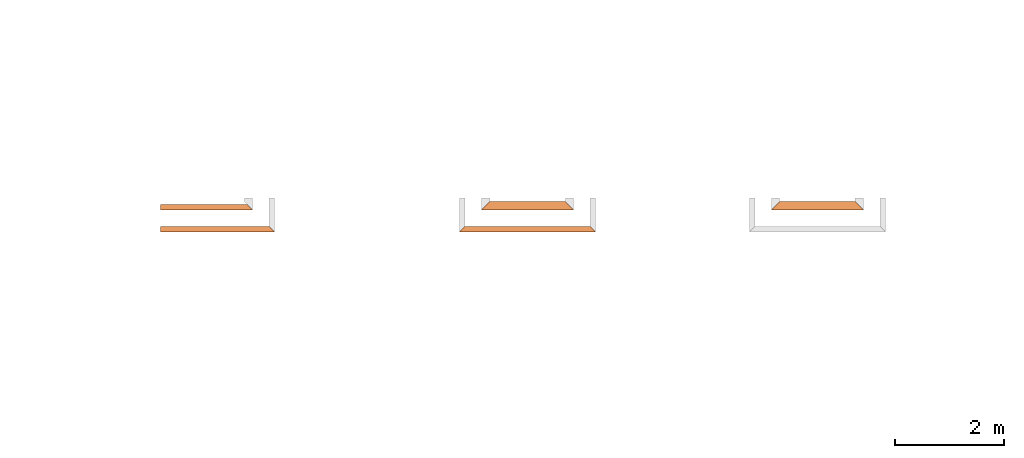
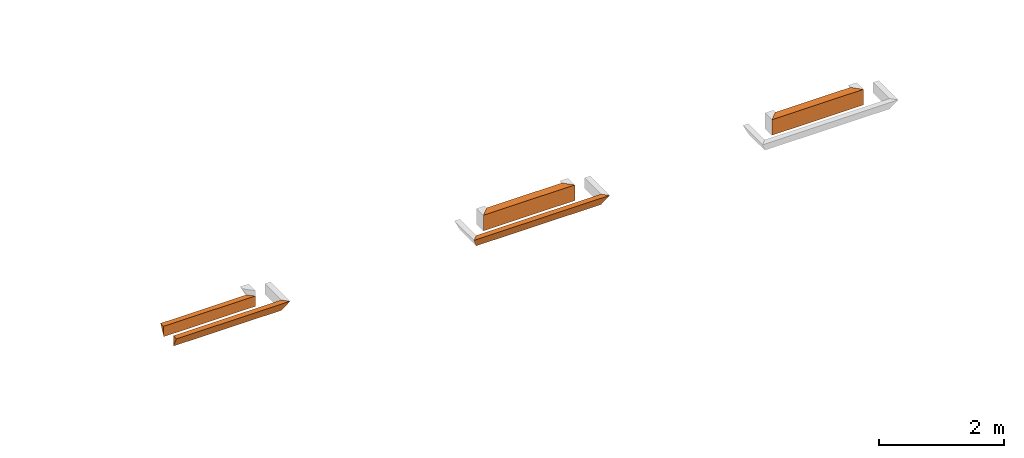
# One storey, part 2 of 8: 5 proxies.
"""IFC4 building model written with IfcOpenShell, lengths in feet."""

import ifcopenshell
import ifcopenshell.guid

model = None  # the IFC model being written
_history = None  # IfcOwnerHistory: only IFC2X3 demands one
_inside = {}  # id of a spatial element -> (the spatial element, [elements in it])
_under = {}  # id of a project, library or spatial element -> (it, [spatial elements below it])
_declared = {}  # id of a project -> (the project, [libraries it declares])
_typed = {}  # id of a type object -> (the type object, [elements of that type])
_made_of = {}  # id of a material, layer set ... -> (it, [elements and type objects made of it])


def new_model(schema):
    """Start an empty IFC model of exactly this schema.

    Asked for "IFC4X3", IfcOpenShell would pick the latest addendum, in which some entities
    have other attributes; the version numbers below select the first issue.
    IFC2X3 requires an IfcOwnerHistory on every rooted entity: one is made here for all.
    """
    global model, _history
    if schema == "IFC4X3":
        model = ifcopenshell.file(schema_version=(4, 3, 0, 0))
    else:
        model = ifcopenshell.file(schema=schema)
    _inside.clear()
    _under.clear()
    _declared.clear()
    _typed.clear()
    _made_of.clear()
    _history = None
    if model.schema == "IFC2X3":
        org = make("IfcOrganization", Name="unknown")
        user = make(
            "IfcPersonAndOrganization",
            ThePerson=make("IfcPerson", FamilyName="unknown"),
            TheOrganization=org,
        )
        app = make(
            "IfcApplication",
            ApplicationDeveloper=org,
            Version="unknown",
            ApplicationFullName="unknown",
            ApplicationIdentifier="unknown",
        )
        _history = make(
            "IfcOwnerHistory",
            OwningUser=user,
            OwningApplication=app,
            ChangeAction="ADDED",
            CreationDate=0,
        )
    return model


def make(cls, **values):
    """One entity of the class cls with the attributes given. An attribute that is None is left unset."""
    return model.create_entity(
        cls, **{name: value for name, value in values.items() if value is not None}
    )


def entity(cls, *values):
    """Any entity or typed value of the class cls, its attributes in the order of the schema. None: left unset."""
    e = model.create_entity(cls)
    for i, value in enumerate(values):
        if value is not None:
            e[i] = value
    return e


def rooted(cls, **values):
    """An entity with a GlobalId (a new one), such as an element, a storey or a relation."""
    return make(cls, GlobalId=ifcopenshell.guid.new(), OwnerHistory=_history, **values)


def si_unit(unit_type, name, prefix=None):
    """IfcSIUnit, for example si_unit("LENGTHUNIT", "METRE", prefix="MILLI")."""
    return make("IfcSIUnit", UnitType=unit_type, Prefix=prefix, Name=name)


def converted_unit(unit_type, name, factor, base, dimensions=None, offset=None):
    """IfcConversionBasedUnit, such as the inch: factor (a typed value) times the base unit."""
    return make(
        "IfcConversionBasedUnit"
        if offset is None
        else "IfcConversionBasedUnitWithOffset",
        ConversionOffset=offset,
        Dimensions=None
        if dimensions is None
        else entity("IfcDimensionalExponents", *dimensions),
        UnitType=unit_type,
        Name=name,
        ConversionFactor=make(
            "IfcMeasureWithUnit", ValueComponent=factor, UnitComponent=base
        ),
    )


def derived_unit(unit_type, elements):
    """IfcDerivedUnit: a product of units, each with its exponent."""
    return make(
        "IfcDerivedUnit",
        Elements=[
            make("IfcDerivedUnitElement", Unit=unit, Exponent=power)
            for unit, power in elements
        ],
        UnitType=unit_type,
    )


def assignment(units):
    """IfcUnitAssignment: the units of a project."""
    return None if units is None else make("IfcUnitAssignment", Units=units)


def point(xyz):
    """IfcCartesianPoint."""
    return None if xyz is None else make("IfcCartesianPoint", Coordinates=xyz)


def direction(xyz):
    """IfcDirection."""
    return None if xyz is None else make("IfcDirection", DirectionRatios=xyz)


def frame(location, z_axis=None, x_axis=None):
    """IfcAxis2Placement3D, a coordinate frame: its origin and axes. An axis left out is left unset."""
    return make(
        "IfcAxis2Placement3D",
        Location=point(location),
        Axis=direction(z_axis),
        RefDirection=direction(x_axis),
    )


def origin():
    """The frame at (0, 0, 0) with its axes left unset."""
    return frame((0.0, 0.0, 0.0))


def place(relative_to, where):
    """IfcLocalPlacement: puts the frame where relative to a parent placement (None: the world)."""
    return make(
        "IfcLocalPlacement", PlacementRelTo=relative_to, RelativePlacement=where
    )


def context(
    kind, dimensions, precision=None, world=None, true_north=None, identifier=None
):
    """IfcGeometricRepresentationContext, for example the 3D "Model" context."""
    return make(
        "IfcGeometricRepresentationContext",
        ContextIdentifier=identifier,
        ContextType=kind,
        CoordinateSpaceDimension=dimensions,
        Precision=precision,
        WorldCoordinateSystem=world,
        TrueNorth=true_north,
    )


def subcontext(parent, identifier, kind, view, scale=None):
    """IfcGeometricRepresentationSubContext, for example "Body" below "Model"."""
    return make(
        "IfcGeometricRepresentationSubContext",
        ContextIdentifier=identifier,
        ContextType=kind,
        ParentContext=parent,
        TargetScale=scale,
        TargetView=view,
    )


def project(units=None, contexts=None):
    """IfcProject with its units and contexts."""
    return rooted(
        "IfcProject",
        Name="project",
        RepresentationContexts=contexts,
        UnitsInContext=assignment(units),
    )


def spatial(cls, under=None, at=None, **own):
    """A site, building, storey or space (cls), placed at a placement, below another one or the project."""
    s = rooted(cls, ObjectPlacement=at, **own)
    if under is not None:
        _under.setdefault(under.id(), (under, []))[1].append(s)
    return s


def shape(context_of_items, identifier, shape_type, items):
    """IfcShapeRepresentation: the items that make up one representation, for example the "Body"."""
    return make(
        "IfcShapeRepresentation",
        ContextOfItems=context_of_items,
        RepresentationIdentifier=identifier,
        RepresentationType=shape_type,
        Items=items,
    )


def made_of(thing, what):
    """Note that an element or type object is made of a material, layer set ...; save() writes the relation."""
    if what is not None:
        _made_of.setdefault(what.id(), (what, []))[1].append(thing)
    return thing


def type_object(cls, material=None, **own):
    """A type object (cls), such as IfcWallType, which elements share."""
    return made_of(rooted(cls, **own), material)


def element(
    cls,
    number,
    at=None,
    inside=None,
    cuts=None,
    type_object=None,
    material=None,
    context=None,
    identifier="Body",
    shape_type=None,
    held_by="IfcProductDefinitionShape",
    body=None,
    shapes=None,
    **own,
):
    """One element of the class cls, such as IfcWall. Its Tag is "e" and its number.

    at: its placement. inside: the storey or other place that contains it. cuts: it is an
    opening in that element (IfcRelVoidsElement). A single representation is given by context,
    identifier, shape_type and body (its items); several are given by shapes. held_by: the class
    of the entity that holds the representations. save() writes the other relations.
    """
    e = rooted(cls, Tag="e%d" % number, ObjectPlacement=at, **own)
    if body is not None:
        shapes = [shape(context, identifier, shape_type, body)]
    if shapes is not None:
        e.Representation = make(held_by, Representations=shapes)
    if inside is not None:
        _inside.setdefault(inside.id(), (inside, []))[1].append(e)
    if cuts is not None:
        rooted(
            "IfcRelVoidsElement", RelatingBuildingElement=cuts, RelatedOpeningElement=e
        )
    if type_object is not None:
        _typed.setdefault(type_object.id(), (type_object, []))[1].append(e)
    return made_of(e, material)


def aggregate(whole, parts):
    """IfcRelAggregates: a whole, such as a stair, and the parts it consists of."""
    return rooted("IfcRelAggregates", RelatingObject=whole, RelatedObjects=parts)


def save(model, path):
    """Write the relations noted so far, then the file.

    IfcRelAggregates (storeys below a building ...), IfcRelContainedInSpatialStructure (elements
    in a storey), IfcRelDefinesByType, IfcRelAssociatesMaterial and IfcRelDeclares: one each for
    every whole, place, type object, material and project.
    """
    for whole, parts in _under.values():
        aggregate(whole, parts)
    for where, things in _inside.values():
        rooted(
            "IfcRelContainedInSpatialStructure",
            RelatedElements=things,
            RelatingStructure=where,
        )
    for kind, things in _typed.values():
        rooted("IfcRelDefinesByType", RelatedObjects=things, RelatingType=kind)
    for what, things in _made_of.values():
        rooted("IfcRelAssociatesMaterial", RelatedObjects=things, RelatingMaterial=what)
    for by, libraries in _declared.values():
        rooted("IfcRelDeclares", RelatingContext=by, RelatedDefinitions=libraries)
    model.write(path)


model = new_model("IFC4")

# Units and contexts
model_context = context("Model", 3, precision=0.0001, world=origin(), true_north=direction((6.12303176911189e-17, 1.0)))
body_context = subcontext(model_context, "Body", "Model", "MODEL_VIEW")
ifc_project = project(units=[converted_unit("LENGTHUNIT", "FOOT", entity("IfcRatioMeasure", 0.3048), si_unit("LENGTHUNIT", "METRE"), dimensions=[1, 0, 0, 0, 0, 0, 0]), converted_unit("AREAUNIT", "SQUARE FOOT", entity("IfcRatioMeasure", 0.09290304), si_unit("AREAUNIT", "SQUARE_METRE"), dimensions=[2, 0, 0, 0, 0, 0, 0]), converted_unit("VOLUMEUNIT", "CUBIC FOOT", entity("IfcRatioMeasure", 0.028316846592), si_unit("VOLUMEUNIT", "CUBIC_METRE"), dimensions=[3, 0, 0, 0, 0, 0, 0]), converted_unit("PLANEANGLEUNIT", "DEGREE", entity("IfcRatioMeasure", 0.0174532925199433), si_unit("PLANEANGLEUNIT", "RADIAN"), dimensions=[0, 0, 0, 0, 0, 0, 0]), si_unit("MASSUNIT", "GRAM", prefix="KILO"), derived_unit("MASSDENSITYUNIT", [(si_unit("MASSUNIT", "GRAM", prefix="KILO"), 1), (si_unit("LENGTHUNIT", "METRE"), -3)]), derived_unit("MOMENTOFINERTIAUNIT", [(si_unit("LENGTHUNIT", "METRE"), 4)]), si_unit("TIMEUNIT", "SECOND"), si_unit("FREQUENCYUNIT", "HERTZ"), si_unit("THERMODYNAMICTEMPERATUREUNIT", "DEGREE_CELSIUS"), derived_unit("THERMALTRANSMITTANCEUNIT", [(si_unit("MASSUNIT", "GRAM", prefix="KILO"), 1), (si_unit("THERMODYNAMICTEMPERATUREUNIT", "KELVIN"), -1), (si_unit("TIMEUNIT", "SECOND"), -3)]), derived_unit("VOLUMETRICFLOWRATEUNIT", [(si_unit("LENGTHUNIT", "METRE"), 3), (si_unit("TIMEUNIT", "SECOND"), -1)]), si_unit("ELECTRICCURRENTUNIT", "AMPERE"), si_unit("ELECTRICVOLTAGEUNIT", "VOLT"), si_unit("POWERUNIT", "WATT"), si_unit("FORCEUNIT", "NEWTON"), si_unit("ILLUMINANCEUNIT", "LUX"), si_unit("LUMINOUSFLUXUNIT", "LUMEN"), si_unit("LUMINOUSINTENSITYUNIT", "CANDELA"), derived_unit("USERDEFINED", [(si_unit("MASSUNIT", "GRAM", prefix="KILO"), -1), (si_unit("LENGTHUNIT", "METRE"), -2), (si_unit("TIMEUNIT", "SECOND"), 3), (si_unit("LUMINOUSFLUXUNIT", "LUMEN"), 1)]), derived_unit("LINEARVELOCITYUNIT", [(si_unit("LENGTHUNIT", "METRE"), 1), (si_unit("TIMEUNIT", "SECOND"), -1)]), si_unit("PRESSUREUNIT", "PASCAL"), derived_unit("USERDEFINED", [(si_unit("LENGTHUNIT", "METRE"), -2), (si_unit("MASSUNIT", "GRAM", prefix="KILO"), 1), (si_unit("TIMEUNIT", "SECOND"), -2)]), derived_unit("LINEARFORCEUNIT", [(si_unit("MASSUNIT", "GRAM", prefix="KILO"), 1), (si_unit("LENGTHUNIT", "METRE"), 1), (si_unit("TIMEUNIT", "SECOND"), -2), (si_unit("LENGTHUNIT", "METRE"), -1)]), derived_unit("PLANARFORCEUNIT", [(si_unit("MASSUNIT", "GRAM", prefix="KILO"), 1), (si_unit("LENGTHUNIT", "METRE"), 1), (si_unit("TIMEUNIT", "SECOND"), -2), (si_unit("LENGTHUNIT", "METRE"), -2)])], contexts=[model_context])

# Site, building, storey
site_placement = place(None, origin())
site = spatial("IfcSite", under=ifc_project, at=site_placement, CompositionType="ELEMENT")
building_placement = place(site_placement, origin())
building = spatial("IfcBuilding", under=site, at=building_placement, CompositionType="ELEMENT")
storey_placement = place(building_placement, frame((0.0, 0.0, -12.6666666666667)))
storey = spatial("IfcBuildingStorey", under=building, at=storey_placement, Name="BASEMENT", CompositionType="ELEMENT", Elevation=-12.6666666666667)

# Proxies
building_element_proxy_type_1 = type_object("IfcBuildingElementProxyType", PredefinedType="NOTDEFINED")
proxy_1_placement = place(storey_placement, frame((-253.238160457323, 957.231726549317, 11.5833333333333)))
cartesian_point_1 = entity("IfcCartesianPoint", [5.54166663846127, 0.0, 0.0])
vertex_point_1 = entity("IfcVertexPoint", cartesian_point_1)
cartesian_point_2 = entity("IfcCartesianPoint", [5.21181447152242, 0.329852166938849, 0.65970433387773])
vertex_point_2 = entity("IfcVertexPoint", cartesian_point_2)
edge_curve_1 = entity("IfcEdgeCurve", vertex_point_1, vertex_point_2, entity("IfcTrimmedCurve", entity("IfcLine", cartesian_point_1, entity("IfcVector", entity("IfcDirection", [-0.408248290463852, 0.408248290463852, 0.816496580927737]), 1.0)), [cartesian_point_1], [cartesian_point_2], True, "CARTESIAN"), True)
cartesian_point_3 = entity("IfcCartesianPoint", [5.54166663846115, 0.0, 0.666576254022283])
vertex_point_3 = entity("IfcVertexPoint", cartesian_point_3)
edge_curve_2 = entity("IfcEdgeCurve", vertex_point_2, vertex_point_3, entity("IfcTrimmedCurve", entity("IfcLine", cartesian_point_2, entity("IfcVector", entity("IfcDirection", [0.707030067676022, -0.707030067676022, 0.0147297930765838]), 1.0)), [cartesian_point_2], [cartesian_point_3], True, "CARTESIAN"), True)
edge_curve_3 = entity("IfcEdgeCurve", vertex_point_3, vertex_point_1, entity("IfcTrimmedCurve", entity("IfcLine", cartesian_point_3, entity("IfcVector", entity("IfcDirection", [0.0, 0.0, -1.0]), 1.0)), [cartesian_point_3], [cartesian_point_1], True, "CARTESIAN"), True)
cartesian_point_4 = entity("IfcCartesianPoint", [0.0, 0.329852166939077, 0.659704333877725])
vertex_point_4 = entity("IfcVertexPoint", cartesian_point_4)
cartesian_point_5 = entity("IfcCartesianPoint", [0.0, 0.0, 0.0])
vertex_point_5 = entity("IfcVertexPoint", cartesian_point_5)
edge_curve_4 = entity("IfcEdgeCurve", vertex_point_4, vertex_point_5, entity("IfcTrimmedCurve", entity("IfcLine", cartesian_point_4, entity("IfcVector", entity("IfcDirection", [0.0, -0.447213595499946, -0.894427190999922]), 1.0)), [cartesian_point_4], [cartesian_point_5], True, "CARTESIAN"), True)
cartesian_point_6 = entity("IfcCartesianPoint", [0.0, 0.0, 0.666576254022285])
vertex_point_6 = entity("IfcVertexPoint", cartesian_point_6)
edge_curve_5 = entity("IfcEdgeCurve", vertex_point_5, vertex_point_6, entity("IfcTrimmedCurve", entity("IfcLine", cartesian_point_5, entity("IfcVector", entity("IfcDirection", [0.0, 0.0, 1.0]), 1.0)), [cartesian_point_5], [cartesian_point_6], True, "CARTESIAN"), True)
edge_curve_6 = entity("IfcEdgeCurve", vertex_point_6, vertex_point_4, entity("IfcTrimmedCurve", entity("IfcLine", cartesian_point_6, entity("IfcVector", entity("IfcDirection", [0.0, 0.999783056728112, -0.0208288136818321]), 1.0)), [cartesian_point_6], [cartesian_point_4], True, "CARTESIAN"), True)
ifc_direction_1 = entity("IfcDirection", [-1.0, 0.0, 0.0])
ifc_direction_2 = entity("IfcDirection", [0.0, -1.0, 0.0])
edge_curve_7 = entity("IfcEdgeCurve", vertex_point_1, vertex_point_5, entity("IfcTrimmedCurve", entity("IfcLine", cartesian_point_1, entity("IfcVector", ifc_direction_1, 1.0)), [cartesian_point_1], [cartesian_point_5], True, "CARTESIAN"), True)
edge_curve_8 = entity("IfcEdgeCurve", vertex_point_4, vertex_point_2, entity("IfcTrimmedCurve", entity("IfcLine", cartesian_point_4, entity("IfcVector", entity("IfcDirection", [1.0, 0.0, 0.0]), 1.0)), [cartesian_point_4], [cartesian_point_2], True, "CARTESIAN"), True)
edge_curve_9 = entity("IfcEdgeCurve", vertex_point_3, vertex_point_6, entity("IfcTrimmedCurve", entity("IfcLine", cartesian_point_3, entity("IfcVector", ifc_direction_1, 1.0)), [cartesian_point_3], [cartesian_point_6], True, "CARTESIAN"), True)
element("IfcBuildingElementProxy", 1, at=proxy_1_placement, inside=storey, type_object=building_element_proxy_type_1, PredefinedType="NOTDEFINED", context=body_context, shape_type="AdvancedBrep", body=[
    entity("IfcAdvancedBrep", entity("IfcClosedShell", [entity("IfcAdvancedFace", [entity("IfcFaceOuterBound", entity("IfcEdgeLoop", [entity("IfcOrientedEdge", None, None, edge_curve_1, True), entity("IfcOrientedEdge", None, None, edge_curve_2, True), entity("IfcOrientedEdge", None, None, edge_curve_3, True)]), True)], entity("IfcPlane", entity("IfcAxis2Placement3D", entity("IfcCartesianPoint", [5.54166663846127, 0.0, 2.0]), entity("IfcDirection", [0.707106781186562, 0.707106781186533, 0.0]), entity("IfcDirection", [-0.707106781186533, 0.707106781186562, 0.0]))), True), entity("IfcAdvancedFace", [entity("IfcFaceOuterBound", entity("IfcEdgeLoop", [entity("IfcOrientedEdge", None, None, edge_curve_4, True), entity("IfcOrientedEdge", None, None, edge_curve_5, True), entity("IfcOrientedEdge", None, None, edge_curve_6, True)]), True)], entity("IfcPlane", entity("IfcAxis2Placement3D", cartesian_point_5, ifc_direction_1, ifc_direction_2)), True), entity("IfcAdvancedFace", [entity("IfcFaceOuterBound", entity("IfcEdgeLoop", [entity("IfcOrientedEdge", None, None, edge_curve_7, True), entity("IfcOrientedEdge", None, None, edge_curve_4, False), entity("IfcOrientedEdge", None, None, edge_curve_8, True), entity("IfcOrientedEdge", None, None, edge_curve_1, False)]), True)], entity("IfcPlane", entity("IfcAxis2Placement3D", cartesian_point_1, entity("IfcDirection", [0.0, 0.894427190999915, -0.447213595499961]), ifc_direction_1)), True), entity("IfcAdvancedFace", [entity("IfcFaceOuterBound", entity("IfcEdgeLoop", [entity("IfcOrientedEdge", None, None, edge_curve_7, False), entity("IfcOrientedEdge", None, None, edge_curve_3, False), entity("IfcOrientedEdge", None, None, edge_curve_9, True), entity("IfcOrientedEdge", None, None, edge_curve_5, False)]), True)], entity("IfcPlane", entity("IfcAxis2Placement3D", entity("IfcCartesianPoint", [5.54166663846127, 0.0, 1.0]), ifc_direction_2, ifc_direction_1)), True), entity("IfcAdvancedFace", [entity("IfcFaceOuterBound", entity("IfcEdgeLoop", [entity("IfcOrientedEdge", None, None, edge_curve_2, False), entity("IfcOrientedEdge", None, None, edge_curve_8, False), entity("IfcOrientedEdge", None, None, edge_curve_6, False), entity("IfcOrientedEdge", None, None, edge_curve_9, False)]), True)], entity("IfcPlane", entity("IfcAxis2Placement3D", cartesian_point_6, entity("IfcDirection", [0.0, 0.0208288136818357, 0.999783056728112]), entity("IfcDirection", [0.0, -0.999783056728112, 0.0208288136818357]))), True)])),
])
building_element_proxy_type_2 = type_object("IfcBuildingElementProxyType", PredefinedType="NOTDEFINED")
proxy_2_placement = place(storey_placement, frame((-253.238160457323, 955.897091132651, 11.5833333333333)))
cartesian_point_7 = entity("IfcCartesianPoint", [6.54166663846127, 0.334635416666742, 0.0])
vertex_point_7 = entity("IfcVertexPoint", cartesian_point_7)
cartesian_point_8 = entity("IfcCartesianPoint", [6.54166663846127, 0.334635416666742, 0.669270833333334])
vertex_point_8 = entity("IfcVertexPoint", cartesian_point_8)
ifc_direction_3 = entity("IfcDirection", [0.0, 0.0, 1.0])
edge_curve_10 = entity("IfcEdgeCurve", vertex_point_7, vertex_point_8, entity("IfcTrimmedCurve", entity("IfcLine", cartesian_point_7, entity("IfcVector", ifc_direction_3, 1.0)), [cartesian_point_7], [cartesian_point_8], True, "CARTESIAN"), True)
cartesian_point_9 = entity("IfcCartesianPoint", [6.87630205512772, 0.0, 0.669270833333334])
vertex_point_9 = entity("IfcVertexPoint", cartesian_point_9)
edge_curve_11 = entity("IfcEdgeCurve", vertex_point_8, vertex_point_9, entity("IfcTrimmedCurve", entity("IfcLine", cartesian_point_8, entity("IfcVector", entity("IfcDirection", [0.707106781186427, -0.707106781186668, 0.0]), 1.0)), [cartesian_point_8], [cartesian_point_9], True, "CARTESIAN"), True)
edge_curve_12 = entity("IfcEdgeCurve", vertex_point_9, vertex_point_7, entity("IfcTrimmedCurve", entity("IfcLine", cartesian_point_9, entity("IfcVector", entity("IfcDirection", [-0.408248290463863, 0.408248290463829, -0.816496580927743]), 1.0)), [cartesian_point_9], [cartesian_point_7], True, "CARTESIAN"), True)
cartesian_point_10 = entity("IfcCartesianPoint", [0.0, 0.33463541666697, 0.0])
vertex_point_10 = entity("IfcVertexPoint", cartesian_point_10)
cartesian_point_11 = entity("IfcCartesianPoint", [0.0, 0.0, 0.669270833333334])
vertex_point_11 = entity("IfcVertexPoint", cartesian_point_11)
edge_curve_13 = entity("IfcEdgeCurve", vertex_point_10, vertex_point_11, entity("IfcTrimmedCurve", entity("IfcLine", cartesian_point_10, entity("IfcVector", entity("IfcDirection", [0.0, -0.44721359549992, 0.894427190999935]), 1.0)), [cartesian_point_10], [cartesian_point_11], True, "CARTESIAN"), True)
cartesian_point_12 = entity("IfcCartesianPoint", [0.0, 0.33463541666697, 0.669270833333334])
vertex_point_12 = entity("IfcVertexPoint", cartesian_point_12)
ifc_direction_4 = entity("IfcDirection", [0.0, 1.0, 0.0])
edge_curve_14 = entity("IfcEdgeCurve", vertex_point_11, vertex_point_12, entity("IfcTrimmedCurve", entity("IfcLine", cartesian_point_11, entity("IfcVector", ifc_direction_4, 1.0)), [cartesian_point_11], [cartesian_point_12], True, "CARTESIAN"), True)
edge_curve_15 = entity("IfcEdgeCurve", vertex_point_12, vertex_point_10, entity("IfcTrimmedCurve", entity("IfcLine", cartesian_point_12, entity("IfcVector", entity("IfcDirection", [0.0, 0.0, -1.0]), 1.0)), [cartesian_point_12], [cartesian_point_10], True, "CARTESIAN"), True)
ifc_direction_5 = entity("IfcDirection", [-1.0, 0.0, 0.0])
edge_curve_16 = entity("IfcEdgeCurve", vertex_point_7, vertex_point_10, entity("IfcTrimmedCurve", entity("IfcLine", cartesian_point_7, entity("IfcVector", ifc_direction_5, 1.0)), [cartesian_point_7], [cartesian_point_10], True, "CARTESIAN"), True)
cartesian_point_13 = entity("IfcCartesianPoint", [5.54166663846127, 0.334635416666742, 0.669270833333334])
vertex_point_13 = entity("IfcVertexPoint", cartesian_point_13)
ifc_direction_6 = entity("IfcDirection", [1.0, 0.0, 0.0])
edge_curve_17 = entity("IfcEdgeCurve", vertex_point_12, vertex_point_13, entity("IfcTrimmedCurve", entity("IfcLine", cartesian_point_12, entity("IfcVector", ifc_direction_6, 1.0)), [cartesian_point_12], [cartesian_point_13], True, "CARTESIAN"), True)
edge_curve_18 = entity("IfcEdgeCurve", vertex_point_13, vertex_point_8, entity("IfcTrimmedCurve", entity("IfcLine", cartesian_point_13, entity("IfcVector", ifc_direction_6, 1.0)), [cartesian_point_13], [cartesian_point_8], True, "CARTESIAN"), True)
edge_curve_19 = entity("IfcEdgeCurve", vertex_point_9, vertex_point_11, entity("IfcTrimmedCurve", entity("IfcLine", cartesian_point_9, entity("IfcVector", ifc_direction_5, 1.0)), [cartesian_point_9], [cartesian_point_11], True, "CARTESIAN"), True)
element("IfcBuildingElementProxy", 2, at=proxy_2_placement, inside=storey, type_object=building_element_proxy_type_2, PredefinedType="NOTDEFINED", context=body_context, shape_type="AdvancedBrep", body=[
    entity("IfcAdvancedBrep", entity("IfcClosedShell", [entity("IfcAdvancedFace", [entity("IfcFaceOuterBound", entity("IfcEdgeLoop", [entity("IfcOrientedEdge", None, None, edge_curve_10, True), entity("IfcOrientedEdge", None, None, edge_curve_11, True), entity("IfcOrientedEdge", None, None, edge_curve_12, True)]), True)], entity("IfcPlane", entity("IfcAxis2Placement3D", entity("IfcCartesianPoint", [6.54166663846127, 0.334635416666742, 2.0]), entity("IfcDirection", [0.707106781186562, 0.707106781186533, 0.0]), entity("IfcDirection", [-0.707106781186533, 0.707106781186562, 0.0]))), True), entity("IfcAdvancedFace", [entity("IfcFaceOuterBound", entity("IfcEdgeLoop", [entity("IfcOrientedEdge", None, None, edge_curve_13, True), entity("IfcOrientedEdge", None, None, edge_curve_14, True), entity("IfcOrientedEdge", None, None, edge_curve_15, True)]), True)], entity("IfcPlane", entity("IfcAxis2Placement3D", cartesian_point_10, ifc_direction_5, entity("IfcDirection", [0.0, -1.0, 0.0]))), True), entity("IfcAdvancedFace", [entity("IfcFaceOuterBound", entity("IfcEdgeLoop", [entity("IfcOrientedEdge", None, None, edge_curve_16, True), entity("IfcOrientedEdge", None, None, edge_curve_15, False), entity("IfcOrientedEdge", None, None, edge_curve_17, True), entity("IfcOrientedEdge", None, None, edge_curve_18, True), entity("IfcOrientedEdge", None, None, edge_curve_10, False)]), True)], entity("IfcPlane", entity("IfcAxis2Placement3D", cartesian_point_7, ifc_direction_4, ifc_direction_5)), True), entity("IfcAdvancedFace", [entity("IfcFaceOuterBound", entity("IfcEdgeLoop", [entity("IfcOrientedEdge", None, None, edge_curve_16, False), entity("IfcOrientedEdge", None, None, edge_curve_12, False), entity("IfcOrientedEdge", None, None, edge_curve_19, True), entity("IfcOrientedEdge", None, None, edge_curve_13, False)]), True)], entity("IfcPlane", entity("IfcAxis2Placement3D", entity("IfcCartesianPoint", [7.04166663846127, -0.165364583333258, 1.0]), entity("IfcDirection", [0.0, -0.894427190999915, -0.447213595499961]), ifc_direction_5)), True), entity("IfcAdvancedFace", [entity("IfcFaceOuterBound", entity("IfcEdgeLoop", [entity("IfcOrientedEdge", None, None, edge_curve_11, False), entity("IfcOrientedEdge", None, None, edge_curve_18, False), entity("IfcOrientedEdge", None, None, edge_curve_17, False), entity("IfcOrientedEdge", None, None, edge_curve_14, False), entity("IfcOrientedEdge", None, None, edge_curve_19, False)]), True)], entity("IfcPlane", entity("IfcAxis2Placement3D", entity("IfcCartesianPoint", [111.500007646349, 2.96484375, 0.669270833333334]), ifc_direction_3, ifc_direction_6)), True)])),
])
building_element_proxy_type_3 = type_object("IfcBuildingElementProxyType", PredefinedType="NOTDEFINED")
proxy_3_placement = place(storey_placement, frame((-233.904827319654, 957.231726549317, 11.5833333333333)))
cartesian_point_14 = entity("IfcCartesianPoint", [5.5416693695779, 0.0, 0.0])
vertex_point_14 = entity("IfcVertexPoint", cartesian_point_14)
cartesian_point_15 = entity("IfcCartesianPoint", [5.0416693695779, 0.5, 1.0])
vertex_point_15 = entity("IfcVertexPoint", cartesian_point_15)
edge_curve_20 = entity("IfcEdgeCurve", vertex_point_14, vertex_point_15, entity("IfcTrimmedCurve", entity("IfcLine", cartesian_point_14, entity("IfcVector", entity("IfcDirection", [-0.408248290463864, 0.408248290463864, 0.816496580927725]), 1.0)), [cartesian_point_14], [cartesian_point_15], True, "CARTESIAN"), True)
cartesian_point_16 = entity("IfcCartesianPoint", [5.5416693695779, 0.0, 1.0])
vertex_point_16 = entity("IfcVertexPoint", cartesian_point_16)
edge_curve_21 = entity("IfcEdgeCurve", vertex_point_15, vertex_point_16, entity("IfcTrimmedCurve", entity("IfcLine", cartesian_point_15, entity("IfcVector", entity("IfcDirection", [0.707106781186547, -0.707106781186547, 0.0]), 1.0)), [cartesian_point_15], [cartesian_point_16], True, "CARTESIAN"), True)
cartesian_point_17 = entity("IfcCartesianPoint", [5.5416693695779, 0.0, 0.669270833333334])
vertex_point_17 = entity("IfcVertexPoint", cartesian_point_17)
ifc_direction_7 = entity("IfcDirection", [0.0, 0.0, -1.0])
edge_curve_22 = entity("IfcEdgeCurve", vertex_point_16, vertex_point_17, entity("IfcTrimmedCurve", entity("IfcLine", cartesian_point_16, entity("IfcVector", ifc_direction_7, 1.0)), [cartesian_point_16], [cartesian_point_17], True, "CARTESIAN"), True)
edge_curve_23 = entity("IfcEdgeCurve", vertex_point_17, vertex_point_14, entity("IfcTrimmedCurve", entity("IfcLine", cartesian_point_17, entity("IfcVector", ifc_direction_7, 1.0)), [cartesian_point_17], [cartesian_point_14], True, "CARTESIAN"), True)
cartesian_point_18 = entity("IfcCartesianPoint", [0.499999999999943, 0.500000000000227, 1.0])
vertex_point_18 = entity("IfcVertexPoint", cartesian_point_18)
cartesian_point_19 = entity("IfcCartesianPoint", [0.0, 0.0, 0.0])
vertex_point_19 = entity("IfcVertexPoint", cartesian_point_19)
edge_curve_24 = entity("IfcEdgeCurve", vertex_point_18, vertex_point_19, entity("IfcTrimmedCurve", entity("IfcLine", cartesian_point_18, entity("IfcVector", entity("IfcDirection", [-0.408248290463845, -0.408248290463868, -0.816496580927732]), 1.0)), [cartesian_point_18], [cartesian_point_19], True, "CARTESIAN"), True)
cartesian_point_20 = entity("IfcCartesianPoint", [0.0, 0.0, 0.669270833333334])
vertex_point_20 = entity("IfcVertexPoint", cartesian_point_20)
ifc_direction_8 = entity("IfcDirection", [0.0, 0.0, 1.0])
edge_curve_25 = entity("IfcEdgeCurve", vertex_point_19, vertex_point_20, entity("IfcTrimmedCurve", entity("IfcLine", cartesian_point_19, entity("IfcVector", ifc_direction_8, 1.0)), [cartesian_point_19], [cartesian_point_20], True, "CARTESIAN"), True)
cartesian_point_21 = entity("IfcCartesianPoint", [0.0, 0.0, 1.0])
vertex_point_21 = entity("IfcVertexPoint", cartesian_point_21)
edge_curve_26 = entity("IfcEdgeCurve", vertex_point_20, vertex_point_21, entity("IfcTrimmedCurve", entity("IfcLine", cartesian_point_20, entity("IfcVector", ifc_direction_8, 1.0)), [cartesian_point_20], [cartesian_point_21], True, "CARTESIAN"), True)
edge_curve_27 = entity("IfcEdgeCurve", vertex_point_21, vertex_point_18, entity("IfcTrimmedCurve", entity("IfcLine", cartesian_point_21, entity("IfcVector", entity("IfcDirection", [0.707106781186527, 0.707106781186568, 0.0]), 1.0)), [cartesian_point_21], [cartesian_point_18], True, "CARTESIAN"), True)
ifc_direction_9 = entity("IfcDirection", [-1.0, 0.0, 0.0])
edge_curve_28 = entity("IfcEdgeCurve", vertex_point_14, vertex_point_19, entity("IfcTrimmedCurve", entity("IfcLine", cartesian_point_14, entity("IfcVector", ifc_direction_9, 1.0)), [cartesian_point_14], [cartesian_point_19], True, "CARTESIAN"), True)
ifc_direction_10 = entity("IfcDirection", [1.0, 0.0, 0.0])
edge_curve_29 = entity("IfcEdgeCurve", vertex_point_18, vertex_point_15, entity("IfcTrimmedCurve", entity("IfcLine", cartesian_point_15, entity("IfcVector", ifc_direction_10, 1.0)), [cartesian_point_18], [cartesian_point_15], True, "CARTESIAN"), True)
edge_curve_30 = entity("IfcEdgeCurve", vertex_point_21, vertex_point_16, entity("IfcTrimmedCurve", entity("IfcLine", cartesian_point_16, entity("IfcVector", ifc_direction_10, 1.0)), [cartesian_point_21], [cartesian_point_16], True, "CARTESIAN"), True)
element("IfcBuildingElementProxy", 3, at=proxy_3_placement, inside=storey, type_object=building_element_proxy_type_3, PredefinedType="NOTDEFINED", context=body_context, shape_type="AdvancedBrep", body=[
    entity("IfcAdvancedBrep", entity("IfcClosedShell", [entity("IfcAdvancedFace", [entity("IfcFaceOuterBound", entity("IfcEdgeLoop", [entity("IfcOrientedEdge", None, None, edge_curve_20, True), entity("IfcOrientedEdge", None, None, edge_curve_21, True), entity("IfcOrientedEdge", None, None, edge_curve_22, True), entity("IfcOrientedEdge", None, None, edge_curve_23, True)]), True)], entity("IfcPlane", entity("IfcAxis2Placement3D", entity("IfcCartesianPoint", [5.5416693695779, 0.0, 2.0]), entity("IfcDirection", [0.707106781186562, 0.707106781186533, 0.0]), entity("IfcDirection", [-0.707106781186533, 0.707106781186562, 0.0]))), True), entity("IfcAdvancedFace", [entity("IfcFaceOuterBound", entity("IfcEdgeLoop", [entity("IfcOrientedEdge", None, None, edge_curve_24, True), entity("IfcOrientedEdge", None, None, edge_curve_25, True), entity("IfcOrientedEdge", None, None, edge_curve_26, True), entity("IfcOrientedEdge", None, None, edge_curve_27, True)]), True)], entity("IfcPlane", entity("IfcAxis2Placement3D", entity("IfcCartesianPoint", [0.0, 0.0, 2.0]), entity("IfcDirection", [-0.707106781186548, 0.707106781186548, 0.0]), entity("IfcDirection", [0.707106781186548, 0.707106781186548, 0.0]))), True), entity("IfcAdvancedFace", [entity("IfcFaceOuterBound", entity("IfcEdgeLoop", [entity("IfcOrientedEdge", None, None, edge_curve_20, False), entity("IfcOrientedEdge", None, None, edge_curve_28, True), entity("IfcOrientedEdge", None, None, edge_curve_24, False), entity("IfcOrientedEdge", None, None, edge_curve_29, True)]), True)], entity("IfcPlane", entity("IfcAxis2Placement3D", cartesian_point_14, entity("IfcDirection", [0.0, 0.894427190999915, -0.447213595499961]), ifc_direction_9)), True), entity("IfcAdvancedFace", [entity("IfcFaceOuterBound", entity("IfcEdgeLoop", [entity("IfcOrientedEdge", None, None, edge_curve_21, False), entity("IfcOrientedEdge", None, None, edge_curve_29, False), entity("IfcOrientedEdge", None, None, edge_curve_27, False), entity("IfcOrientedEdge", None, None, edge_curve_30, True)]), True)], entity("IfcPlane", entity("IfcAxis2Placement3D", cartesian_point_15, ifc_direction_8, ifc_direction_9)), True), entity("IfcAdvancedFace", [entity("IfcFaceOuterBound", entity("IfcEdgeLoop", [entity("IfcOrientedEdge", None, None, edge_curve_30, False), entity("IfcOrientedEdge", None, None, edge_curve_26, False), entity("IfcOrientedEdge", None, None, edge_curve_25, False), entity("IfcOrientedEdge", None, None, edge_curve_28, False), entity("IfcOrientedEdge", None, None, edge_curve_23, False), entity("IfcOrientedEdge", None, None, edge_curve_22, False)]), True)], entity("IfcPlane", entity("IfcAxis2Placement3D", cartesian_point_16, entity("IfcDirection", [0.0, -1.0, 0.0]), ifc_direction_9)), True)])),
])
building_element_proxy_type_4 = type_object("IfcBuildingElementProxyType", PredefinedType="NOTDEFINED")
proxy_4_placement = place(storey_placement, frame((-235.239462736321, 955.89709113265, 11.5833333333333)))
cartesian_point_22 = entity("IfcCartesianPoint", [7.8763047862445, 0.334635416666629, 0.0])
vertex_point_22 = entity("IfcVertexPoint", cartesian_point_22)
cartesian_point_23 = entity("IfcCartesianPoint", [7.8763047862445, 0.334635416666629, 0.669270833333334])
vertex_point_23 = entity("IfcVertexPoint", cartesian_point_23)
ifc_direction_11 = entity("IfcDirection", [0.0, 0.0, 1.0])
edge_curve_31 = entity("IfcEdgeCurve", vertex_point_22, vertex_point_23, entity("IfcTrimmedCurve", entity("IfcLine", cartesian_point_22, entity("IfcVector", ifc_direction_11, 1.0)), [cartesian_point_22], [cartesian_point_23], True, "CARTESIAN"), True)
cartesian_point_24 = entity("IfcCartesianPoint", [8.21094020291105, 0.0, 0.669270833333334])
vertex_point_24 = entity("IfcVertexPoint", cartesian_point_24)
edge_curve_32 = entity("IfcEdgeCurve", vertex_point_23, vertex_point_24, entity("IfcTrimmedCurve", entity("IfcLine", cartesian_point_23, entity("IfcVector", entity("IfcDirection", [0.707106781186517, -0.707106781186578, 0.0]), 1.0)), [cartesian_point_23], [cartesian_point_24], True, "CARTESIAN"), True)
edge_curve_33 = entity("IfcEdgeCurve", vertex_point_24, vertex_point_22, entity("IfcTrimmedCurve", entity("IfcLine", cartesian_point_24, entity("IfcVector", entity("IfcDirection", [-0.408248290463863, 0.408248290463829, -0.816496580927743]), 1.0)), [cartesian_point_24], [cartesian_point_22], True, "CARTESIAN"), True)
cartesian_point_25 = entity("IfcCartesianPoint", [0.334635416666742, 0.33463541666697, 0.0])
vertex_point_25 = entity("IfcVertexPoint", cartesian_point_25)
cartesian_point_26 = entity("IfcCartesianPoint", [0.0, 0.0, 0.669270833333334])
vertex_point_26 = entity("IfcVertexPoint", cartesian_point_26)
edge_curve_34 = entity("IfcEdgeCurve", vertex_point_25, vertex_point_26, entity("IfcTrimmedCurve", entity("IfcLine", cartesian_point_25, entity("IfcVector", entity("IfcDirection", [-0.408248290463863, -0.408248290463829, 0.816496580927743]), 1.0)), [cartesian_point_25], [cartesian_point_26], True, "CARTESIAN"), True)
cartesian_point_27 = entity("IfcCartesianPoint", [0.334635416666742, 0.33463541666697, 0.669270833333334])
vertex_point_27 = entity("IfcVertexPoint", cartesian_point_27)
edge_curve_35 = entity("IfcEdgeCurve", vertex_point_26, vertex_point_27, entity("IfcTrimmedCurve", entity("IfcLine", cartesian_point_26, entity("IfcVector", entity("IfcDirection", [0.707106781186517, 0.707106781186578, 0.0]), 1.0)), [cartesian_point_26], [cartesian_point_27], True, "CARTESIAN"), True)
edge_curve_36 = entity("IfcEdgeCurve", vertex_point_27, vertex_point_25, entity("IfcTrimmedCurve", entity("IfcLine", cartesian_point_27, entity("IfcVector", entity("IfcDirection", [0.0, 0.0, -1.0]), 1.0)), [cartesian_point_27], [cartesian_point_25], True, "CARTESIAN"), True)
ifc_direction_12 = entity("IfcDirection", [-1.0, 0.0, 0.0])
edge_curve_37 = entity("IfcEdgeCurve", vertex_point_22, vertex_point_25, entity("IfcTrimmedCurve", entity("IfcLine", cartesian_point_22, entity("IfcVector", ifc_direction_12, 1.0)), [cartesian_point_22], [cartesian_point_25], True, "CARTESIAN"), True)
cartesian_point_28 = entity("IfcCartesianPoint", [1.33463541666663, 0.33463541666697, 0.669270833333334])
vertex_point_28 = entity("IfcVertexPoint", cartesian_point_28)
ifc_direction_13 = entity("IfcDirection", [1.0, 0.0, 0.0])
edge_curve_38 = entity("IfcEdgeCurve", vertex_point_27, vertex_point_28, entity("IfcTrimmedCurve", entity("IfcLine", cartesian_point_27, entity("IfcVector", ifc_direction_13, 1.0)), [cartesian_point_27], [cartesian_point_28], True, "CARTESIAN"), True)
cartesian_point_29 = entity("IfcCartesianPoint", [2.58463558470353, 0.334635416666856, 0.669270833333334])
vertex_point_29 = entity("IfcVertexPoint", cartesian_point_29)
edge_curve_39 = entity("IfcEdgeCurve", vertex_point_28, vertex_point_29, entity("IfcTrimmedCurve", entity("IfcLine", cartesian_point_28, entity("IfcVector", ifc_direction_13, 1.0)), [cartesian_point_28], [cartesian_point_29], True, "CARTESIAN"), True)
cartesian_point_30 = entity("IfcCartesianPoint", [3.75130225137019, 0.334635416666856, 0.669270833333334])
vertex_point_30 = entity("IfcVertexPoint", cartesian_point_30)
edge_curve_40 = entity("IfcEdgeCurve", vertex_point_29, vertex_point_30, entity("IfcTrimmedCurve", entity("IfcLine", cartesian_point_29, entity("IfcVector", ifc_direction_13, 1.0)), [cartesian_point_29], [cartesian_point_30], True, "CARTESIAN"), True)
cartesian_point_31 = entity("IfcCartesianPoint", [6.8763047862445, 0.334635416666629, 0.669270833333334])
vertex_point_31 = entity("IfcVertexPoint", cartesian_point_31)
edge_curve_41 = entity("IfcEdgeCurve", vertex_point_30, vertex_point_31, entity("IfcTrimmedCurve", entity("IfcLine", cartesian_point_30, entity("IfcVector", ifc_direction_13, 1.0)), [cartesian_point_30], [cartesian_point_31], True, "CARTESIAN"), True)
edge_curve_42 = entity("IfcEdgeCurve", vertex_point_31, vertex_point_23, entity("IfcTrimmedCurve", entity("IfcLine", cartesian_point_31, entity("IfcVector", ifc_direction_13, 1.0)), [cartesian_point_31], [cartesian_point_23], True, "CARTESIAN"), True)
edge_curve_43 = entity("IfcEdgeCurve", vertex_point_24, vertex_point_26, entity("IfcTrimmedCurve", entity("IfcLine", cartesian_point_24, entity("IfcVector", ifc_direction_12, 1.0)), [cartesian_point_24], [cartesian_point_26], True, "CARTESIAN"), True)
element("IfcBuildingElementProxy", 4, at=proxy_4_placement, inside=storey, type_object=building_element_proxy_type_4, PredefinedType="NOTDEFINED", context=body_context, shape_type="AdvancedBrep", body=[
    entity("IfcAdvancedBrep", entity("IfcClosedShell", [entity("IfcAdvancedFace", [entity("IfcFaceOuterBound", entity("IfcEdgeLoop", [entity("IfcOrientedEdge", None, None, edge_curve_31, True), entity("IfcOrientedEdge", None, None, edge_curve_32, True), entity("IfcOrientedEdge", None, None, edge_curve_33, True)]), True)], entity("IfcPlane", entity("IfcAxis2Placement3D", entity("IfcCartesianPoint", [7.8763047862445, 0.334635416666629, 2.0]), entity("IfcDirection", [0.707106781186562, 0.707106781186533, 0.0]), entity("IfcDirection", [-0.707106781186533, 0.707106781186562, 0.0]))), True), entity("IfcAdvancedFace", [entity("IfcFaceOuterBound", entity("IfcEdgeLoop", [entity("IfcOrientedEdge", None, None, edge_curve_34, True), entity("IfcOrientedEdge", None, None, edge_curve_35, True), entity("IfcOrientedEdge", None, None, edge_curve_36, True)]), True)], entity("IfcPlane", entity("IfcAxis2Placement3D", entity("IfcCartesianPoint", [0.334635416666629, 0.334635416666856, 2.0]), entity("IfcDirection", [-0.707106781186548, 0.707106781186548, 0.0]), entity("IfcDirection", [0.707106781186548, 0.707106781186548, 0.0]))), True), entity("IfcAdvancedFace", [entity("IfcFaceOuterBound", entity("IfcEdgeLoop", [entity("IfcOrientedEdge", None, None, edge_curve_37, True), entity("IfcOrientedEdge", None, None, edge_curve_36, False), entity("IfcOrientedEdge", None, None, edge_curve_38, True), entity("IfcOrientedEdge", None, None, edge_curve_39, True), entity("IfcOrientedEdge", None, None, edge_curve_40, True), entity("IfcOrientedEdge", None, None, edge_curve_41, True), entity("IfcOrientedEdge", None, None, edge_curve_42, True), entity("IfcOrientedEdge", None, None, edge_curve_31, False)]), True)], entity("IfcPlane", entity("IfcAxis2Placement3D", cartesian_point_22, entity("IfcDirection", [0.0, 1.0, 0.0]), ifc_direction_12)), True), entity("IfcAdvancedFace", [entity("IfcFaceOuterBound", entity("IfcEdgeLoop", [entity("IfcOrientedEdge", None, None, edge_curve_37, False), entity("IfcOrientedEdge", None, None, edge_curve_33, False), entity("IfcOrientedEdge", None, None, edge_curve_43, True), entity("IfcOrientedEdge", None, None, edge_curve_34, False)]), True)], entity("IfcPlane", entity("IfcAxis2Placement3D", entity("IfcCartesianPoint", [8.3763047862445, -0.165364583333371, 1.0]), entity("IfcDirection", [0.0, -0.894427190999915, -0.447213595499961]), ifc_direction_12)), True), entity("IfcAdvancedFace", [entity("IfcFaceOuterBound", entity("IfcEdgeLoop", [entity("IfcOrientedEdge", None, None, edge_curve_32, False), entity("IfcOrientedEdge", None, None, edge_curve_42, False), entity("IfcOrientedEdge", None, None, edge_curve_41, False), entity("IfcOrientedEdge", None, None, edge_curve_40, False), entity("IfcOrientedEdge", None, None, edge_curve_39, False), entity("IfcOrientedEdge", None, None, edge_curve_38, False), entity("IfcOrientedEdge", None, None, edge_curve_35, False), entity("IfcOrientedEdge", None, None, edge_curve_43, False)]), True)], entity("IfcPlane", entity("IfcAxis2Placement3D", entity("IfcCartesianPoint", [93.5013099253467, 2.96484375000057, 0.669270833333334]), ifc_direction_11, ifc_direction_13)), True)])),
])
building_element_proxy_type_5 = type_object("IfcBuildingElementProxyType", PredefinedType="NOTDEFINED")
proxy_5_placement = place(storey_placement, frame((-216.446494139458, 957.231726549316, 11.5833333333333)))
cartesian_point_32 = entity("IfcCartesianPoint", [5.54166715472138, 0.0, 0.0])
vertex_point_32 = entity("IfcVertexPoint", cartesian_point_32)
cartesian_point_33 = entity("IfcCartesianPoint", [5.04166715472138, 0.5, 1.0])
vertex_point_33 = entity("IfcVertexPoint", cartesian_point_33)
edge_curve_44 = entity("IfcEdgeCurve", vertex_point_32, vertex_point_33, entity("IfcTrimmedCurve", entity("IfcLine", cartesian_point_32, entity("IfcVector", entity("IfcDirection", [-0.408248290463864, 0.408248290463864, 0.816496580927725]), 1.0)), [cartesian_point_32], [cartesian_point_33], True, "CARTESIAN"), True)
cartesian_point_34 = entity("IfcCartesianPoint", [5.54166715472138, 0.0, 1.0])
vertex_point_34 = entity("IfcVertexPoint", cartesian_point_34)
edge_curve_45 = entity("IfcEdgeCurve", vertex_point_33, vertex_point_34, entity("IfcTrimmedCurve", entity("IfcLine", cartesian_point_33, entity("IfcVector", entity("IfcDirection", [0.707106781186547, -0.707106781186547, 0.0]), 1.0)), [cartesian_point_33], [cartesian_point_34], True, "CARTESIAN"), True)
cartesian_point_35 = entity("IfcCartesianPoint", [5.54166715472138, 0.0, 0.669270833333334])
vertex_point_35 = entity("IfcVertexPoint", cartesian_point_35)
ifc_direction_14 = entity("IfcDirection", [0.0, 0.0, -1.0])
edge_curve_46 = entity("IfcEdgeCurve", vertex_point_34, vertex_point_35, entity("IfcTrimmedCurve", entity("IfcLine", cartesian_point_34, entity("IfcVector", ifc_direction_14, 1.0)), [cartesian_point_34], [cartesian_point_35], True, "CARTESIAN"), True)
edge_curve_47 = entity("IfcEdgeCurve", vertex_point_35, vertex_point_32, entity("IfcTrimmedCurve", entity("IfcLine", cartesian_point_35, entity("IfcVector", ifc_direction_14, 1.0)), [cartesian_point_35], [cartesian_point_32], True, "CARTESIAN"), True)
cartesian_point_36 = entity("IfcCartesianPoint", [0.499999999999972, 0.500000000000227, 1.0])
vertex_point_36 = entity("IfcVertexPoint", cartesian_point_36)
cartesian_point_37 = entity("IfcCartesianPoint", [0.0, 0.0, 0.0])
vertex_point_37 = entity("IfcVertexPoint", cartesian_point_37)
edge_curve_48 = entity("IfcEdgeCurve", vertex_point_36, vertex_point_37, entity("IfcTrimmedCurve", entity("IfcLine", cartesian_point_36, entity("IfcVector", entity("IfcDirection", [-0.408248290463845, -0.408248290463868, -0.816496580927732]), 1.0)), [cartesian_point_36], [cartesian_point_37], True, "CARTESIAN"), True)
cartesian_point_38 = entity("IfcCartesianPoint", [0.0, 0.0, 0.669270833333334])
vertex_point_38 = entity("IfcVertexPoint", cartesian_point_38)
ifc_direction_15 = entity("IfcDirection", [0.0, 0.0, 1.0])
edge_curve_49 = entity("IfcEdgeCurve", vertex_point_37, vertex_point_38, entity("IfcTrimmedCurve", entity("IfcLine", cartesian_point_37, entity("IfcVector", ifc_direction_15, 1.0)), [cartesian_point_37], [cartesian_point_38], True, "CARTESIAN"), True)
cartesian_point_39 = entity("IfcCartesianPoint", [0.0, 0.0, 1.0])
vertex_point_39 = entity("IfcVertexPoint", cartesian_point_39)
edge_curve_50 = entity("IfcEdgeCurve", vertex_point_38, vertex_point_39, entity("IfcTrimmedCurve", entity("IfcLine", cartesian_point_38, entity("IfcVector", ifc_direction_15, 1.0)), [cartesian_point_38], [cartesian_point_39], True, "CARTESIAN"), True)
edge_curve_51 = entity("IfcEdgeCurve", vertex_point_39, vertex_point_36, entity("IfcTrimmedCurve", entity("IfcLine", cartesian_point_39, entity("IfcVector", entity("IfcDirection", [0.707106781186527, 0.707106781186568, 0.0]), 1.0)), [cartesian_point_39], [cartesian_point_36], True, "CARTESIAN"), True)
ifc_direction_16 = entity("IfcDirection", [-1.0, 0.0, 0.0])
edge_curve_52 = entity("IfcEdgeCurve", vertex_point_32, vertex_point_37, entity("IfcTrimmedCurve", entity("IfcLine", cartesian_point_32, entity("IfcVector", ifc_direction_16, 1.0)), [cartesian_point_32], [cartesian_point_37], True, "CARTESIAN"), True)
ifc_direction_17 = entity("IfcDirection", [1.0, 0.0, 0.0])
edge_curve_53 = entity("IfcEdgeCurve", vertex_point_36, vertex_point_33, entity("IfcTrimmedCurve", entity("IfcLine", cartesian_point_33, entity("IfcVector", ifc_direction_17, 1.0)), [cartesian_point_36], [cartesian_point_33], True, "CARTESIAN"), True)
edge_curve_54 = entity("IfcEdgeCurve", vertex_point_39, vertex_point_34, entity("IfcTrimmedCurve", entity("IfcLine", cartesian_point_34, entity("IfcVector", ifc_direction_17, 1.0)), [cartesian_point_39], [cartesian_point_34], True, "CARTESIAN"), True)
element("IfcBuildingElementProxy", 5, at=proxy_5_placement, inside=storey, type_object=building_element_proxy_type_5, PredefinedType="NOTDEFINED", context=body_context, shape_type="AdvancedBrep", body=[
    entity("IfcAdvancedBrep", entity("IfcClosedShell", [entity("IfcAdvancedFace", [entity("IfcFaceOuterBound", entity("IfcEdgeLoop", [entity("IfcOrientedEdge", None, None, edge_curve_44, True), entity("IfcOrientedEdge", None, None, edge_curve_45, True), entity("IfcOrientedEdge", None, None, edge_curve_46, True), entity("IfcOrientedEdge", None, None, edge_curve_47, True)]), True)], entity("IfcPlane", entity("IfcAxis2Placement3D", entity("IfcCartesianPoint", [5.54166715472138, 0.0, 2.0]), entity("IfcDirection", [0.707106781186562, 0.707106781186533, 0.0]), entity("IfcDirection", [-0.707106781186533, 0.707106781186562, 0.0]))), True), entity("IfcAdvancedFace", [entity("IfcFaceOuterBound", entity("IfcEdgeLoop", [entity("IfcOrientedEdge", None, None, edge_curve_48, True), entity("IfcOrientedEdge", None, None, edge_curve_49, True), entity("IfcOrientedEdge", None, None, edge_curve_50, True), entity("IfcOrientedEdge", None, None, edge_curve_51, True)]), True)], entity("IfcPlane", entity("IfcAxis2Placement3D", entity("IfcCartesianPoint", [0.0, 0.0, 2.0]), entity("IfcDirection", [-0.707106781186548, 0.707106781186548, 0.0]), entity("IfcDirection", [0.707106781186548, 0.707106781186548, 0.0]))), True), entity("IfcAdvancedFace", [entity("IfcFaceOuterBound", entity("IfcEdgeLoop", [entity("IfcOrientedEdge", None, None, edge_curve_44, False), entity("IfcOrientedEdge", None, None, edge_curve_52, True), entity("IfcOrientedEdge", None, None, edge_curve_48, False), entity("IfcOrientedEdge", None, None, edge_curve_53, True)]), True)], entity("IfcPlane", entity("IfcAxis2Placement3D", cartesian_point_32, entity("IfcDirection", [0.0, 0.894427190999915, -0.447213595499961]), ifc_direction_16)), True), entity("IfcAdvancedFace", [entity("IfcFaceOuterBound", entity("IfcEdgeLoop", [entity("IfcOrientedEdge", None, None, edge_curve_45, False), entity("IfcOrientedEdge", None, None, edge_curve_53, False), entity("IfcOrientedEdge", None, None, edge_curve_51, False), entity("IfcOrientedEdge", None, None, edge_curve_54, True)]), True)], entity("IfcPlane", entity("IfcAxis2Placement3D", cartesian_point_33, ifc_direction_15, ifc_direction_16)), True), entity("IfcAdvancedFace", [entity("IfcFaceOuterBound", entity("IfcEdgeLoop", [entity("IfcOrientedEdge", None, None, edge_curve_54, False), entity("IfcOrientedEdge", None, None, edge_curve_50, False), entity("IfcOrientedEdge", None, None, edge_curve_49, False), entity("IfcOrientedEdge", None, None, edge_curve_52, False), entity("IfcOrientedEdge", None, None, edge_curve_47, False), entity("IfcOrientedEdge", None, None, edge_curve_46, False)]), True)], entity("IfcPlane", entity("IfcAxis2Placement3D", cartesian_point_34, entity("IfcDirection", [0.0, -1.0, 0.0]), ifc_direction_16)), True)])),
])

save(model, "model.ifc")
